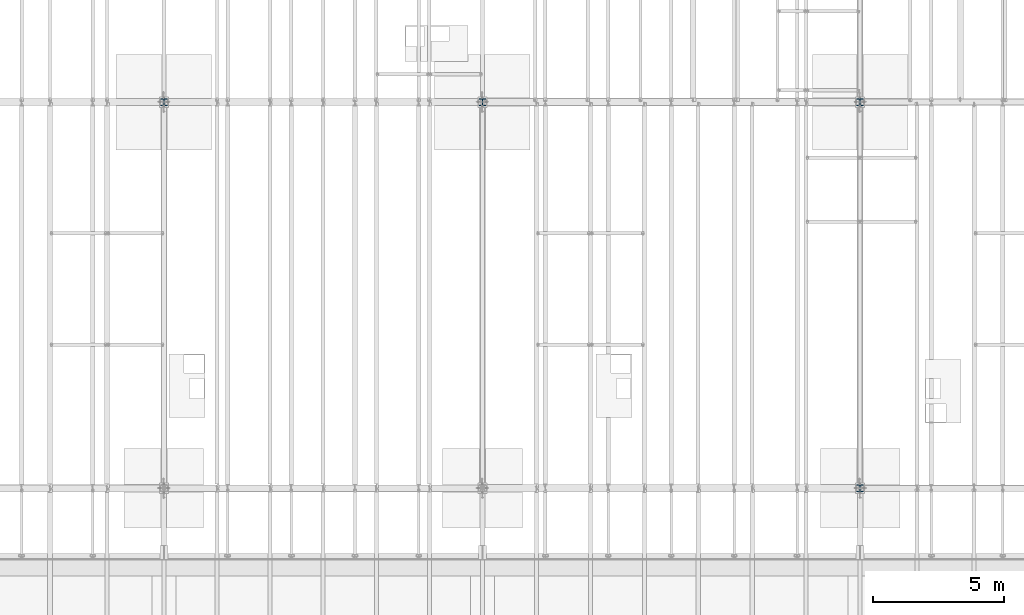
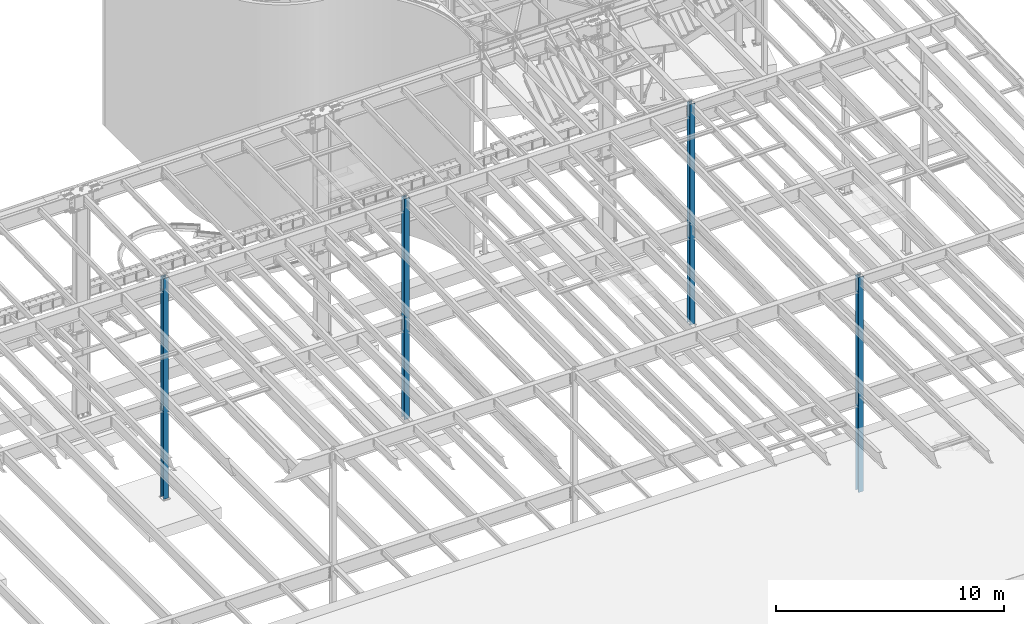
# One storey, part 909 of 1763: 4 columns, 4 elements without a shape of their own.
"""IFC2X3 building model written with IfcOpenShell, lengths in millimetres."""

from ifc_helpers import new_model, si_unit, frame, origin_with_axes, place, context, subcontext, project, spatial, faceted_brep, material, type_object, element, aggregate, save


model = new_model("IFC2X3")

# Units and contexts
model_context = context("Model", 3, precision=1e-05, world=origin_with_axes())
body_context = subcontext(model_context, "Body", "Model", "MODEL_VIEW")
ifc_project = project(units=[si_unit("LENGTHUNIT", "METRE", prefix="MILLI"), si_unit("AREAUNIT", "SQUARE_METRE"), si_unit("VOLUMEUNIT", "CUBIC_METRE"), si_unit("MASSUNIT", "GRAM", prefix="KILO"), si_unit("TIMEUNIT", "SECOND"), si_unit("PLANEANGLEUNIT", "RADIAN"), si_unit("SOLIDANGLEUNIT", "STERADIAN"), si_unit("THERMODYNAMICTEMPERATUREUNIT", "DEGREE_CELSIUS"), si_unit("LUMINOUSINTENSITYUNIT", "LUMEN")], contexts=[model_context])

# Site, building, storey
site_placement = place(None, origin_with_axes())
site = spatial("IfcSite", under=ifc_project, at=site_placement, CompositionType="ELEMENT")
building_placement = place(site_placement, origin_with_axes())
building = spatial("IfcBuilding", under=site, at=building_placement, Name="Undefined", CompositionType="ELEMENT")
storey_placement = place(building_placement, origin_with_axes())
storey = spatial("IfcBuildingStorey", under=building, at=storey_placement, Name="Undefined", CompositionType="ELEMENT", Elevation=0.0)

# Assembly, column
assembly_1_placement = place(storey_placement, origin_with_axes())
assembly_1 = element("IfcElementAssembly", 1, at=assembly_1_placement, inside=storey, Name="COLUMN", AssemblyPlace="NOTDEFINED", PredefinedType="RIGID_FRAME")
ifc_material = material(Name="STEEL/A992")
column_type = type_object("IfcColumnType", Name="W10X68", PredefinedType="NOTDEFINED")
column_1_placement = place(assembly_1_placement, frame((-34949.8372736984, 30022.8, -304.8), z_axis=(0.0, 1.0, 0.0), x_axis=(0.0, 0.0, 1.0)))
column_1 = element("IfcColumn", 2, at=column_1_placement, type_object=column_type, material=ifc_material, Name="COLUMN", ObjectType="W10X68", context=body_context, shape_type="Brep", body=[
    faceted_brep([(69.8499999999952, 128.587499999994, -131.762500000001), (69.8499999999952, 128.587499999994, -112.712500000001), (11582.3999999952, 128.587499999994, -112.712500000001), (11582.3999999952, 128.587499999994, -131.762500000001), (69.8499999999952, 6.35000000000582, -112.712500000001), (11582.3999999952, 6.35000000000582, -112.712500000001), (69.8499999999952, 6.35000000000582, 112.712500000001), (11582.3999999952, 6.35000000000582, 112.712500000001), (69.8499999999952, 128.587499999994, 112.712500000001), (11582.3999999952, 128.587499999994, 112.712500000001), (69.8499999999952, 128.587499999994, 131.762500000001), (11582.3999999952, 128.587499999994, 131.762500000001), (69.8499999999952, -128.587499999994, 131.762500000001), (11582.3999999952, -128.587499999994, 131.762500000001), (69.8499999999952, -128.587499999994, 112.712500000001), (11582.3999999952, -128.587499999994, 112.712500000001), (69.8499999999952, -6.35000000000582, 112.712500000001), (11582.3999999952, -6.35000000000582, 112.712500000001), (69.8499999999952, -6.35000000000582, -112.712500000001), (11582.3999999952, -6.35000000000582, -112.712500000001), (69.8499999999952, -128.587499999994, -112.712500000001), (11582.3999999952, -128.587499999994, -112.712500000001), (69.8499999999952, -128.587499999994, -131.762500000001), (11582.3999999952, -128.587499999994, -131.762500000001)], [[[0, 1, 2, 3]], [[1, 4, 5, 2]], [[4, 6, 7, 5]], [[6, 8, 9, 7]], [[8, 10, 11, 9]], [[10, 12, 13, 11]], [[12, 14, 15, 13]], [[14, 16, 17, 15]], [[16, 18, 19, 17]], [[18, 20, 21, 19]], [[20, 22, 23, 21]], [[22, 0, 3, 23]], [[5, 7, 9, 11, 13, 15, 17, 19, 21, 23, 3, 2]], [[22, 20, 18, 16, 14, 12, 10, 8, 6, 4, 1, 0]]]),
])
aggregate(assembly_1, [column_1])

assembly_2_placement = place(storey_placement, origin_with_axes())
assembly_2 = element("IfcElementAssembly", 3, at=assembly_2_placement, inside=storey, Name="COLUMN", AssemblyPlace="NOTDEFINED", PredefinedType="RIGID_FRAME")
column_2_placement = place(assembly_2_placement, frame((-34949.8372736984, 44805.6, -304.8), z_axis=(0.0, 1.0, 0.0), x_axis=(0.0, 0.0, 1.0)))
column_2 = element("IfcColumn", 4, at=column_2_placement, type_object=column_type, material=ifc_material, Name="COLUMN", ObjectType="W10X68", context=body_context, shape_type="Brep", body=[
    faceted_brep([(69.8499999999952, 128.587499999994, -131.762500000001), (69.8499999999952, 128.587499999994, -112.712500000001), (11887.795312, 128.587500000001, -112.712500000001), (11887.795312, 128.587500000001, -131.762499999997), (69.8499999999952, 6.35000000000582, -112.712500000001), (11887.795312, 6.34999999999854, -112.712500000001), (69.8499999999952, 6.35000000000582, 112.712500000001), (11887.795312, 6.34999999999854, 112.712500000001), (69.8499999999952, 128.587499999994, 112.712500000001), (11887.795312, 128.587500000001, 112.712500000001), (69.8499999999952, 128.587499999994, 131.762500000001), (11887.795312, 128.587500000001, 131.762499999997), (69.8499999999952, -128.587499999994, 131.762500000001), (11887.795312, -128.587500000001, 131.762499999997), (69.8499999999952, -128.587499999994, 112.712500000001), (11887.795312, -128.587500000001, 112.712500000001), (69.8499999999952, -6.35000000000582, 112.712500000001), (11887.795312, -6.34999999999854, 112.712500000001), (69.8499999999952, -6.35000000000582, -112.712500000001), (11887.795312, -6.34999999999854, -112.712500000001), (69.8499999999952, -128.587499999994, -112.712500000001), (11887.795312, -128.587500000001, -112.712500000001), (69.8499999999952, -128.587499999994, -131.762500000001), (11887.795312, -128.587500000001, -131.762499999997)], [[[0, 1, 2, 3]], [[1, 4, 5, 2]], [[4, 6, 7, 5]], [[6, 8, 9, 7]], [[8, 10, 11, 9]], [[10, 12, 13, 11]], [[12, 14, 15, 13]], [[14, 16, 17, 15]], [[16, 18, 19, 17]], [[18, 20, 21, 19]], [[20, 22, 23, 21]], [[22, 0, 3, 23]], [[5, 7, 9, 11, 13, 15, 17, 19, 21, 23, 3, 2]], [[22, 20, 18, 16, 14, 12, 10, 8, 6, 4, 1, 0]]]),
])
aggregate(assembly_2, [column_2])

assembly_3_placement = place(storey_placement, origin_with_axes())
assembly_3 = element("IfcElementAssembly", 5, at=assembly_3_placement, inside=storey, Name="COLUMN", AssemblyPlace="NOTDEFINED", PredefinedType="RIGID_FRAME")
column_3_placement = place(assembly_3_placement, frame((-49402.4372736983, 44805.6, -304.8), z_axis=(0.0, 1.0, 0.0), x_axis=(0.0, 0.0, 1.0)))
column_3 = element("IfcColumn", 6, at=column_3_placement, type_object=column_type, material=ifc_material, Name="COLUMN", ObjectType="W10X68", context=body_context, shape_type="Brep", body=[
    faceted_brep([(69.8499999999952, 128.587499999994, -131.762500000001), (69.8499999999952, 128.587499999994, -112.712500000001), (11887.795312, 128.587500000001, -112.712500000001), (11887.795312, 128.587500000001, -131.762499999997), (69.8499999999952, 6.35000000000582, -112.712500000001), (11887.795312, 6.34999999999854, -112.712500000001), (69.8499999999952, 6.35000000000582, 112.712500000001), (11887.795312, 6.34999999999854, 112.712500000001), (69.8499999999952, 128.587499999994, 112.712500000001), (11887.795312, 128.587500000001, 112.712500000001), (69.8499999999952, 128.587499999994, 131.762500000001), (11887.795312, 128.587500000001, 131.762499999997), (69.8499999999952, -128.587499999994, 131.762500000001), (11887.795312, -128.587500000001, 131.762499999997), (69.8499999999952, -128.587499999994, 112.712500000001), (11887.795312, -128.587500000001, 112.712500000001), (69.8499999999952, -6.35000000000582, 112.712500000001), (11887.795312, -6.34999999999854, 112.712500000001), (69.8499999999952, -6.35000000000582, -112.712500000001), (11887.795312, -6.34999999999854, -112.712500000001), (69.8499999999952, -128.587499999994, -112.712500000001), (11887.795312, -128.587500000001, -112.712500000001), (69.8499999999952, -128.587499999994, -131.762500000001), (11887.795312, -128.587500000001, -131.762499999997)], [[[0, 1, 2, 3]], [[1, 4, 5, 2]], [[4, 6, 7, 5]], [[6, 8, 9, 7]], [[8, 10, 11, 9]], [[10, 12, 13, 11]], [[12, 14, 15, 13]], [[14, 16, 17, 15]], [[16, 18, 19, 17]], [[18, 20, 21, 19]], [[20, 22, 23, 21]], [[22, 0, 3, 23]], [[5, 7, 9, 11, 13, 15, 17, 19, 21, 23, 3, 2]], [[22, 20, 18, 16, 14, 12, 10, 8, 6, 4, 1, 0]]]),
])
aggregate(assembly_3, [column_3])

assembly_4_placement = place(storey_placement, origin_with_axes())
assembly_4 = element("IfcElementAssembly", 7, at=assembly_4_placement, inside=storey, Name="COLUMN", AssemblyPlace="NOTDEFINED", PredefinedType="RIGID_FRAME")
column_4_placement = place(assembly_4_placement, frame((-61594.4372736983, 44805.6, -304.8), z_axis=(0.0, 1.0, 0.0), x_axis=(0.0, 0.0, 1.0)))
column_4 = element("IfcColumn", 8, at=column_4_placement, type_object=column_type, material=ifc_material, Name="COLUMN", ObjectType="W10X68", context=body_context, shape_type="Brep", body=[
    faceted_brep([(69.8499999999952, 128.587499999994, -131.762500000001), (69.8499999999952, 128.587499999994, -112.712500000001), (11887.795312, 128.587500000001, -112.712500000001), (11887.795312, 128.587500000001, -131.762499999997), (69.8499999999952, 6.35000000000582, -112.712500000001), (11887.795312, 6.34999999999854, -112.712500000001), (69.8499999999952, 6.35000000000582, 112.712500000001), (11887.795312, 6.34999999999854, 112.712500000001), (69.8499999999952, 128.587499999994, 112.712500000001), (11887.795312, 128.587500000001, 112.712500000001), (69.8499999999952, 128.587499999994, 131.762500000001), (11887.795312, 128.587500000001, 131.762499999997), (69.8499999999952, -128.587499999994, 131.762500000001), (11887.795312, -128.587500000001, 131.762499999997), (69.8499999999952, -128.587499999994, 112.712500000001), (11887.795312, -128.587500000001, 112.712500000001), (69.8499999999952, -6.35000000000582, 112.712500000001), (11887.795312, -6.34999999999854, 112.712500000001), (69.8499999999952, -6.35000000000582, -112.712500000001), (11887.795312, -6.34999999999854, -112.712500000001), (69.8499999999952, -128.587499999994, -112.712500000001), (11887.795312, -128.587500000001, -112.712500000001), (69.8499999999952, -128.587499999994, -131.762500000001), (11887.795312, -128.587500000001, -131.762499999997)], [[[0, 1, 2, 3]], [[1, 4, 5, 2]], [[4, 6, 7, 5]], [[6, 8, 9, 7]], [[8, 10, 11, 9]], [[10, 12, 13, 11]], [[12, 14, 15, 13]], [[14, 16, 17, 15]], [[16, 18, 19, 17]], [[18, 20, 21, 19]], [[20, 22, 23, 21]], [[22, 0, 3, 23]], [[5, 7, 9, 11, 13, 15, 17, 19, 21, 23, 3, 2]], [[22, 20, 18, 16, 14, 12, 10, 8, 6, 4, 1, 0]]]),
])
aggregate(assembly_4, [column_4])

save(model, "model.ifc")
